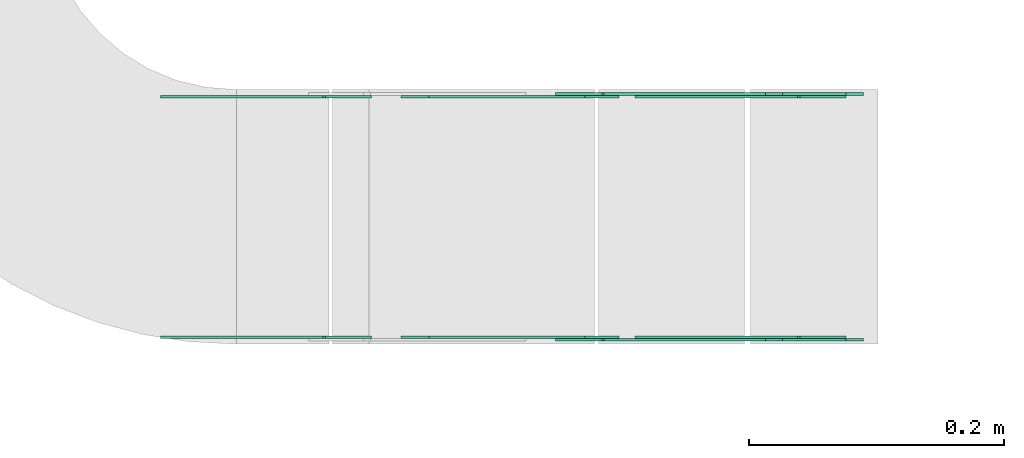
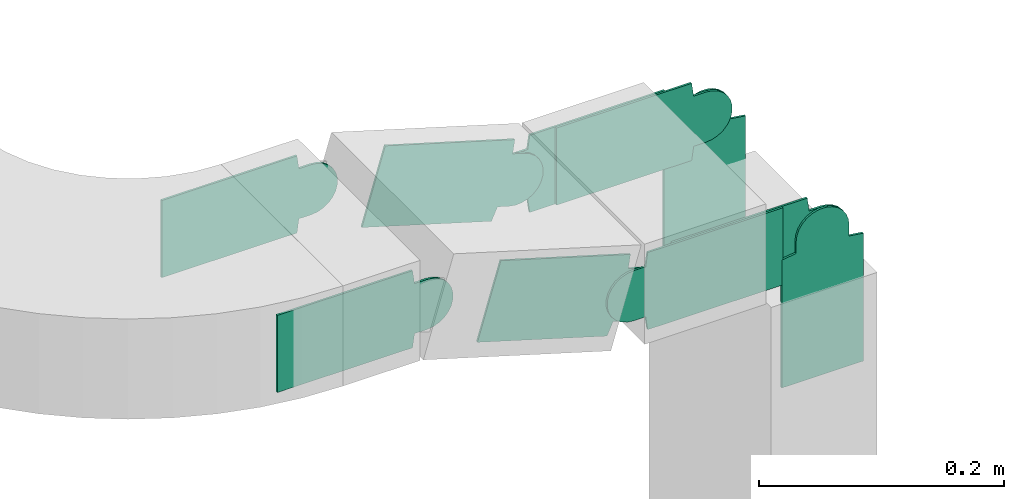
# One storey, part 14 of 28: 10 flow fittings.
"""IFC2X3 building model written with IfcOpenShell, lengths in millimetres."""

from ifc_helpers import new_model, entity, si_unit, converted_unit, derived_unit, direction, frame, frame_2d, origin, place, context, subcontext, project, spatial, polyline, circle_curve, parameter, trimmed, segment, composite_curve, outline, extrude, source, transform, mapped, material, type_object, type_shapes, element, save


model = new_model("IFC2X3")

# Units and contexts
model_context = context("Model", 3, precision=0.01, world=origin(), true_north=direction((6.12303176911189e-17, 1.0)))
body_context = subcontext(model_context, "Body", "Model", "MODEL_VIEW")
ifc_project = project(units=[si_unit("LENGTHUNIT", "METRE", prefix="MILLI"), si_unit("AREAUNIT", "SQUARE_METRE"), si_unit("VOLUMEUNIT", "CUBIC_METRE"), converted_unit("PLANEANGLEUNIT", "DEGREE", entity("IfcRatioMeasure", 0.0174532925199433), si_unit("PLANEANGLEUNIT", "RADIAN"), dimensions=[0, 0, 0, 0, 0, 0, 0]), si_unit("MASSUNIT", "GRAM", prefix="KILO"), derived_unit("MASSDENSITYUNIT", [(si_unit("MASSUNIT", "GRAM", prefix="KILO"), 1), (si_unit("LENGTHUNIT", "METRE"), -3)]), derived_unit("MOMENTOFINERTIAUNIT", [(si_unit("LENGTHUNIT", "METRE"), 4)]), si_unit("TIMEUNIT", "SECOND"), si_unit("FREQUENCYUNIT", "HERTZ"), si_unit("THERMODYNAMICTEMPERATUREUNIT", "DEGREE_CELSIUS"), derived_unit("THERMALTRANSMITTANCEUNIT", [(si_unit("MASSUNIT", "GRAM", prefix="KILO"), 1), (si_unit("THERMODYNAMICTEMPERATUREUNIT", "KELVIN"), -1), (si_unit("TIMEUNIT", "SECOND"), -3)]), derived_unit("VOLUMETRICFLOWRATEUNIT", [(si_unit("LENGTHUNIT", "METRE"), 3), (si_unit("TIMEUNIT", "SECOND"), -1)]), derived_unit("MASSFLOWRATEUNIT", [(si_unit("MASSUNIT", "GRAM", prefix="KILO"), 1), (si_unit("TIMEUNIT", "SECOND"), -1)]), derived_unit("ROTATIONALFREQUENCYUNIT", [(si_unit("TIMEUNIT", "SECOND"), -1)]), si_unit("ELECTRICCURRENTUNIT", "AMPERE"), si_unit("ELECTRICVOLTAGEUNIT", "VOLT"), si_unit("POWERUNIT", "WATT"), si_unit("FORCEUNIT", "NEWTON", prefix="KILO"), si_unit("ILLUMINANCEUNIT", "LUX"), si_unit("LUMINOUSFLUXUNIT", "LUMEN"), si_unit("LUMINOUSINTENSITYUNIT", "CANDELA"), derived_unit("USERDEFINED", [(si_unit("MASSUNIT", "GRAM", prefix="KILO"), -1), (si_unit("LENGTHUNIT", "METRE"), -2), (si_unit("TIMEUNIT", "SECOND"), 3), (si_unit("LUMINOUSFLUXUNIT", "LUMEN"), 1)]), derived_unit("LINEARVELOCITYUNIT", [(si_unit("LENGTHUNIT", "METRE"), 1), (si_unit("TIMEUNIT", "SECOND"), -1)]), si_unit("PRESSUREUNIT", "PASCAL"), derived_unit("USERDEFINED", [(si_unit("LENGTHUNIT", "METRE"), -2), (si_unit("MASSUNIT", "GRAM", prefix="KILO"), 1), (si_unit("TIMEUNIT", "SECOND"), -2)]), derived_unit("LINEARFORCEUNIT", [(si_unit("MASSUNIT", "GRAM", prefix="KILO"), 1), (si_unit("LENGTHUNIT", "METRE"), 1), (si_unit("TIMEUNIT", "SECOND"), -2), (si_unit("LENGTHUNIT", "METRE"), -1)]), derived_unit("PLANARFORCEUNIT", [(si_unit("MASSUNIT", "GRAM", prefix="KILO"), 1), (si_unit("LENGTHUNIT", "METRE"), 1), (si_unit("TIMEUNIT", "SECOND"), -2), (si_unit("LENGTHUNIT", "METRE"), -2)])], contexts=[model_context])

# Site, building, storey
site_placement = place(None, origin())
site = spatial("IfcSite", under=ifc_project, at=site_placement, CompositionType="ELEMENT")
building_placement = place(site_placement, origin())
building = spatial("IfcBuilding", under=site, at=building_placement, CompositionType="ELEMENT")
storey_placement = place(building_placement, frame((0.0, 0.0, 4200.0)))
storey = spatial("IfcBuildingStorey", under=building, at=storey_placement, CompositionType="ELEMENT", Elevation=4200.0)

# Flow fittings
ifc_material = material(Name="G")
cable_carrier_fitting_type_1 = type_object("IfcCableCarrierFittingType", PredefinedType="NOTDEFINED", material=ifc_material)
shared_shape_1 = source(origin(), body_context, "Body", "SweptSolid", [
    extrude(outline(composite_curve([segment(trimmed(circle_curve(frame_2d((-41.47, 0.0), x_axis=(1.0, 0.0)), 25.0), [parameter(90.0000000000007)], [parameter(270.0)], True, "PARAMETER"), True, "CONTINUOUS"), segment(polyline([(-41.47, -25.0), (-29.97, -25.0)]), True, "CONTINUOUS"), segment(polyline([(-29.97, -25.0), (-28.1, -38.5)]), True, "CONTINUOUS"), segment(polyline([(-28.1, -38.5), (99.53, -38.5)]), True, "CONTINUOUS"), segment(polyline([(99.53, -38.5), (99.53, 38.5)]), True, "CONTINUOUS"), segment(polyline([(99.53, 38.5), (-28.1, 38.5)]), True, "CONTINUOUS"), segment(polyline([(-28.1, 38.5), (-29.97, 25.0)]), True, "CONTINUOUS"), segment(polyline([(-29.97, 25.0), (-41.47, 25.0)]), True, "CONTINUOUS")], self_intersect=False)), frame((41.47, 0.0, 0.0), z_axis=(0.0, 0.0, -1.0), x_axis=(1.0, 0.0, 0.0)), (0.0, 0.0, -1.0), 2.0),
])
type_shapes(cable_carrier_fitting_type_1, [shared_shape_1])
flow_fitting_1_placement = place(storey_placement, frame((27363.72, 7531.54, 2980.0), z_axis=(0.0, -1.0, 0.0), x_axis=(-1.0, 0.0, 0.0)))
element("IfcFlowFitting", 1, at=flow_fitting_1_placement, inside=storey, type_object=cable_carrier_fitting_type_1, material=ifc_material, context=body_context, shape_type="MappedRepresentation", body=[
    mapped(shared_shape_1, transform((0.0, 0.0, 0.0), scale=1.0)),
])
cable_carrier_fitting_type_2 = type_object("IfcCableCarrierFittingType", PredefinedType="NOTDEFINED", material=ifc_material)
type_shapes(cable_carrier_fitting_type_2, [shared_shape_1])
flow_fitting_2_placement = place(storey_placement, frame((27557.78, 7529.54, 2921.96), z_axis=(0.0, -1.0, 0.0), x_axis=(1.0, 0.0, 0.0)))
element("IfcFlowFitting", 2, at=flow_fitting_2_placement, inside=storey, type_object=cable_carrier_fitting_type_2, material=ifc_material, context=body_context, shape_type="MappedRepresentation", body=[
    mapped(shared_shape_1, transform((0.0, 0.0, 0.0), scale=1.0)),
])
flow_fitting_3_placement = place(storey_placement, frame((27557.78, 7718.46, 2921.96), z_axis=(0.0, 1.0, 0.0), x_axis=(-0.958072371883606, 0.0, 0.286526316825037)))
element("IfcFlowFitting", 3, at=flow_fitting_3_placement, inside=storey, type_object=cable_carrier_fitting_type_1, material=ifc_material, context=body_context, shape_type="MappedRepresentation", body=[
    mapped(shared_shape_1, transform((0.0, 0.0, 0.0), scale=1.0)),
])
flow_fitting_4_placement = place(storey_placement, frame((27736.22, 7720.46, 2921.96), z_axis=(0.0, 1.0, 0.0), x_axis=(0.0, 0.0, -1.0)))
element("IfcFlowFitting", 4, at=flow_fitting_4_placement, inside=storey, type_object=cable_carrier_fitting_type_2, material=ifc_material, context=body_context, shape_type="MappedRepresentation", body=[
    mapped(shared_shape_1, transform((0.0, 0.0, 0.0), scale=1.0)),
])
flow_fitting_5_placement = place(storey_placement, frame((27736.22, 7531.54, 2921.96), z_axis=(0.0, -1.0, 0.0), x_axis=(-1.0, 0.0, 0.0)))
element("IfcFlowFitting", 5, at=flow_fitting_5_placement, inside=storey, type_object=cable_carrier_fitting_type_1, material=ifc_material, context=body_context, shape_type="MappedRepresentation", body=[
    mapped(shared_shape_1, transform((0.0, 0.0, 0.0), scale=1.0)),
])
cable_carrier_fitting_type_3 = type_object("IfcCableCarrierFittingType", PredefinedType="NOTDEFINED", material=ifc_material)
shared_shape_2 = source(origin(), body_context, "Body", "SweptSolid", [
    extrude(outline(composite_curve([segment(trimmed(circle_curve(frame_2d((-41.47, 0.0), x_axis=(1.0, 0.0)), 25.0), [parameter(90.0000000000007)], [parameter(270.0)], True, "PARAMETER"), True, "CONTINUOUS"), segment(polyline([(-41.47, -25.0), (-29.97, -25.0)]), True, "CONTINUOUS"), segment(polyline([(-29.97, -25.0), (-28.1, -38.5)]), True, "CONTINUOUS"), segment(polyline([(-28.1, -38.5), (99.53, -38.5)]), True, "CONTINUOUS"), segment(polyline([(99.53, -38.5), (99.53, 38.5)]), True, "CONTINUOUS"), segment(polyline([(99.53, 38.5), (-28.1, 38.5)]), True, "CONTINUOUS"), segment(polyline([(-28.1, 38.5), (-29.97, 25.0)]), True, "CONTINUOUS"), segment(polyline([(-29.97, 25.0), (-41.47, 25.0)]), True, "CONTINUOUS")], self_intersect=False)), frame((41.47, 0.0, 0.0)), (0.0, 0.0, 1.0), 2.0),
])
type_shapes(cable_carrier_fitting_type_3, [shared_shape_2])
flow_fitting_6_placement = place(storey_placement, frame((27363.72, 7718.46, 2980.0), z_axis=(0.0, 1.0, 0.0), x_axis=(-1.0, 0.0, 0.0)))
element("IfcFlowFitting", 6, at=flow_fitting_6_placement, inside=storey, type_object=cable_carrier_fitting_type_3, material=ifc_material, context=body_context, shape_type="MappedRepresentation", body=[
    mapped(shared_shape_2, transform((0.0, 0.0, 0.0), scale=1.0)),
])
cable_carrier_fitting_type_4 = type_object("IfcCableCarrierFittingType", PredefinedType="NOTDEFINED", material=ifc_material)
type_shapes(cable_carrier_fitting_type_4, [shared_shape_2])
flow_fitting_7_placement = place(storey_placement, frame((27557.78, 7720.46, 2921.96), z_axis=(0.0, 1.0, 0.0), x_axis=(1.0, 0.0, 0.0)))
element("IfcFlowFitting", 7, at=flow_fitting_7_placement, inside=storey, type_object=cable_carrier_fitting_type_4, material=ifc_material, context=body_context, shape_type="MappedRepresentation", body=[
    mapped(shared_shape_2, transform((0.0, 0.0, 0.0), scale=1.0)),
])
flow_fitting_8_placement = place(storey_placement, frame((27557.78, 7531.54, 2921.96), z_axis=(0.0, -1.0, 0.0), x_axis=(-0.958072371883606, 0.0, 0.286526316825037)))
element("IfcFlowFitting", 8, at=flow_fitting_8_placement, inside=storey, type_object=cable_carrier_fitting_type_3, material=ifc_material, context=body_context, shape_type="MappedRepresentation", body=[
    mapped(shared_shape_2, transform((0.0, 0.0, 0.0), scale=1.0)),
])
flow_fitting_9_placement = place(storey_placement, frame((27736.22, 7529.54, 2921.96), z_axis=(0.0, -1.0, 0.0), x_axis=(0.0, 0.0, -1.0)))
element("IfcFlowFitting", 9, at=flow_fitting_9_placement, inside=storey, type_object=cable_carrier_fitting_type_4, material=ifc_material, context=body_context, shape_type="MappedRepresentation", body=[
    mapped(shared_shape_2, transform((0.0, 0.0, 0.0), scale=1.0)),
])
flow_fitting_10_placement = place(storey_placement, frame((27736.22, 7718.46, 2921.96), z_axis=(0.0, 1.0, 0.0), x_axis=(-1.0, 0.0, 0.0)))
element("IfcFlowFitting", 10, at=flow_fitting_10_placement, inside=storey, type_object=cable_carrier_fitting_type_3, material=ifc_material, context=body_context, shape_type="MappedRepresentation", body=[
    mapped(shared_shape_2, transform((0.0, 0.0, 0.0), scale=1.0)),
])

save(model, "model.ifc")
